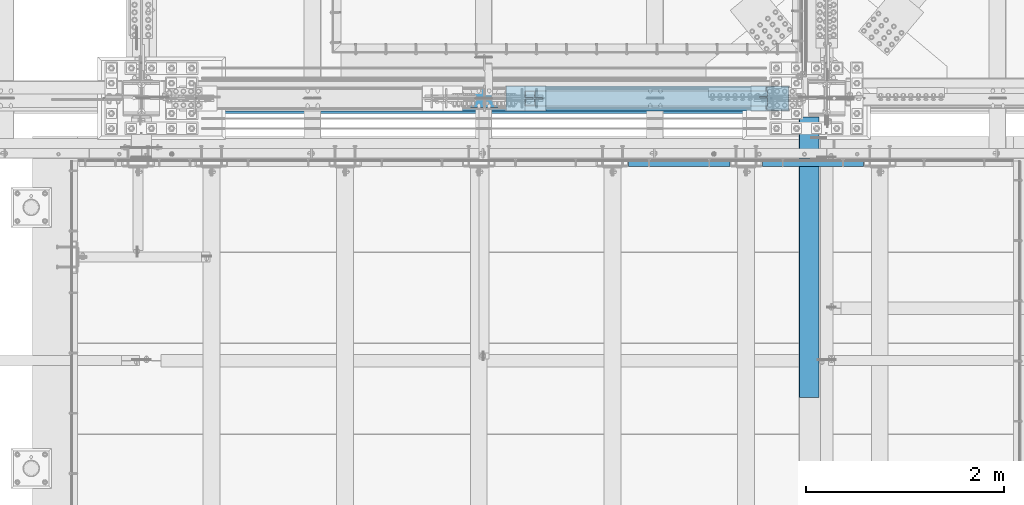
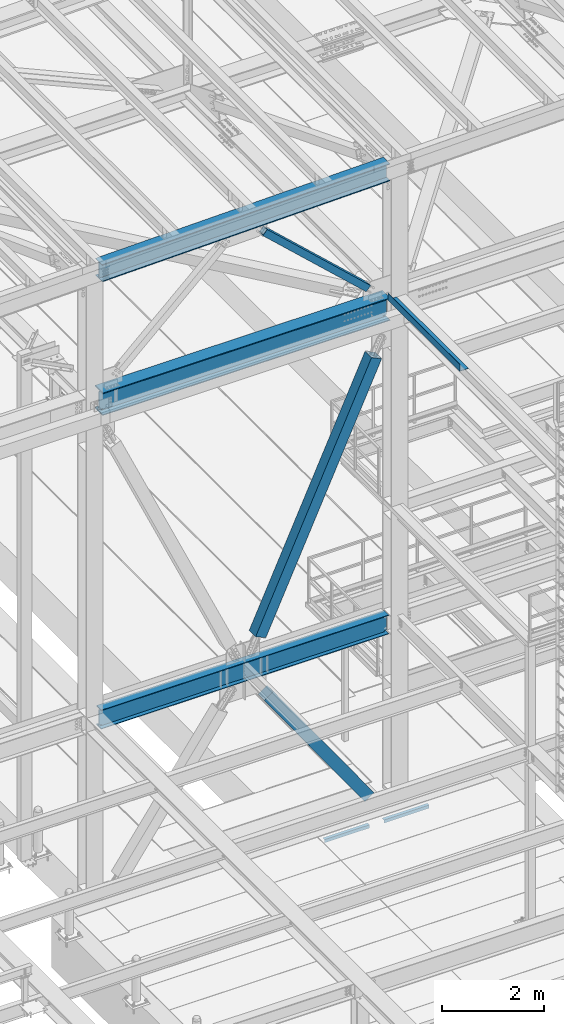
# One storey, part 1779 of 3843: 6 beams, 3 members, 9 elements without a shape of their own.
"""IFC2X3 building model written with IfcOpenShell, lengths in millimetres."""

from ifc_helpers import new_model, si_unit, frame, origin_with_axes, place, context, subcontext, project, spatial, faceted_brep, material, type_object, element, aggregate, save


model = new_model("IFC2X3")

# Units and contexts
model_context = context("Model", 3, precision=1e-05, world=origin_with_axes())
body_context = subcontext(model_context, "Body", "Model", "MODEL_VIEW")
ifc_project = project(units=[si_unit("LENGTHUNIT", "METRE", prefix="MILLI"), si_unit("AREAUNIT", "SQUARE_METRE"), si_unit("VOLUMEUNIT", "CUBIC_METRE"), si_unit("MASSUNIT", "GRAM", prefix="KILO"), si_unit("TIMEUNIT", "SECOND"), si_unit("PLANEANGLEUNIT", "RADIAN"), si_unit("SOLIDANGLEUNIT", "STERADIAN"), si_unit("THERMODYNAMICTEMPERATUREUNIT", "DEGREE_CELSIUS"), si_unit("LUMINOUSINTENSITYUNIT", "LUMEN")], contexts=[model_context])

# Site, building, storey
site_placement = place(None, origin_with_axes())
site = spatial("IfcSite", under=ifc_project, at=site_placement, CompositionType="ELEMENT")
building_placement = place(site_placement, origin_with_axes())
building = spatial("IfcBuilding", under=site, at=building_placement, Name="Undefined", CompositionType="ELEMENT")
storey_placement = place(building_placement, origin_with_axes())
storey = spatial("IfcBuildingStorey", under=building, at=storey_placement, Name="Undefined", CompositionType="ELEMENT", Elevation=0.0)

# Assembly, beam
assembly_1_placement = place(storey_placement, origin_with_axes())
assembly_1 = element("IfcElementAssembly", 1, at=assembly_1_placement, inside=storey, Name="ANGLE", AssemblyPlace="NOTDEFINED", PredefinedType="RIGID_FRAME")
ifc_material_1 = material(Name="STEEL/A36")
beam_type_1 = type_object("IfcBeamType", Name="L3X3X1/4", PredefinedType="NOTDEFINED")
beam_1_placement = place(assembly_1_placement, frame((48345.7242797851, 24961.8499971387, 30365.7000030518), z_axis=(0.0, 0.0, -1.0), x_axis=(1.0, 0.0, 0.0)))
beam_1 = element("IfcBeam", 2, at=beam_1_placement, type_object=beam_type_1, material=ifc_material_1, Name="ANGLE", ObjectType="L3X3X1/4", context=body_context, shape_type="Brep", body=[
    faceted_brep([(0.0, 38.0999999999985, -38.0999999999985), (0.0, 38.0999999999985, 38.0999999999985), (1022.33317453146, 38.1000000000004, 38.0999999999985), (1022.33317453146, 38.1000000000004, -38.0999999999985), (0.0, 31.75, 38.0999999999985), (1022.33317453146, 31.75, 38.0999999999985), (0.0, 31.75, -31.75), (1022.33317453146, 31.75, -31.75), (0.0, -38.0999999999985, -31.75), (1022.33317453146, -38.1000000000004, -31.75), (0.0, -38.0999999999985, -38.0999999999985), (1022.33317453146, -38.1000000000004, -38.0999999999985)], [[[0, 1, 2, 3]], [[1, 4, 5, 2]], [[4, 6, 7, 5]], [[6, 8, 9, 7]], [[8, 10, 11, 9]], [[10, 0, 3, 11]], [[5, 7, 9, 11, 3, 2]], [[10, 8, 6, 4, 1, 0]]]),
])
aggregate(assembly_1, [beam_1])

assembly_2_placement = place(storey_placement, origin_with_axes())
assembly_2 = element("IfcElementAssembly", 3, at=assembly_2_placement, inside=storey, Name="ANGLE", AssemblyPlace="NOTDEFINED", PredefinedType="RIGID_FRAME")
beam_2_placement = place(assembly_2_placement, frame((46993.1742797851, 24961.8499970339, 30365.7000030518), z_axis=(0.0, 0.0, -1.0), x_axis=(1.0, 0.0, 0.0)))
beam_2 = element("IfcBeam", 4, at=beam_2_placement, type_object=beam_type_1, material=ifc_material_1, Name="ANGLE", ObjectType="L3X3X1/4", context=body_context, shape_type="Brep", body=[
    faceted_brep([(0.0, 38.0999999999985, -38.0999999999985), (0.0, 38.0999999999985, 38.0999999999985), (1022.33317453146, 38.1000000000004, 38.0999999999985), (1022.33317453146, 38.1000000000004, -38.0999999999985), (0.0, 31.75, 38.0999999999985), (1022.33317453146, 31.75, 38.0999999999985), (0.0, 31.75, -31.75), (1022.33317453146, 31.75, -31.75), (0.0, -38.0999999999985, -31.75), (1022.33317453146, -38.1000000000004, -31.75), (0.0, -38.0999999999985, -38.0999999999985), (1022.33317453146, -38.1000000000004, -38.0999999999985)], [[[0, 1, 2, 3]], [[1, 4, 5, 2]], [[4, 6, 7, 5]], [[6, 8, 9, 7]], [[8, 10, 11, 9]], [[10, 0, 3, 11]], [[5, 7, 9, 11, 3, 2]], [[10, 8, 6, 4, 1, 0]]]),
])
aggregate(assembly_2, [beam_2])

assembly_3_placement = place(storey_placement, origin_with_axes())
assembly_3 = element("IfcElementAssembly", 5, at=assembly_3_placement, inside=storey, Name="BEAM", AssemblyPlace="NOTDEFINED", PredefinedType="RIGID_FRAME")
ifc_material_2 = material(Name="STEEL/A992")
beam_type_2 = type_object("IfcBeamType", Name="W21X101", PredefinedType="NOTDEFINED")
beam_3_placement = place(assembly_3_placement, frame((42062.4, 25615.8999999454, 42197.3375000034), z_axis=(0.0, 0.0, 1.0), x_axis=(1.0, 0.0, 0.0)))
beam_3 = element("IfcBeam", 6, at=beam_3_placement, type_object=beam_type_2, material=ifc_material_2, Name="BEAM", ObjectType="W21X101", context=body_context, shape_type="Brep", body=[
    faceted_brep([(6740.525, 6.35000000000218, 215.900000000001), (6733.19265158327, -6.34999999999854, 215.900000000001), (6733.19265158327, -6.34999999999854, -215.900000000001), (6740.525, 6.34999999999854, -215.900000000001), (6728.61039888389, 155.575000000001, 271.462500000001), (6740.525, 155.575000000001, 250.824999999997), (193.675000000003, 155.575000000001, 250.824999999997), (205.589601116109, 155.575000000001, 271.462500000001), (6740.525, 6.34999999999854, 250.824999999997), (193.675000000003, 6.35000000000036, 250.824999999997), (6740.525, -155.575000000001, -271.462500000001), (6728.61038401834, -155.575000000001, -250.824999999997), (205.589615981677, -155.575000000001, -250.824999999997), (193.675000000003, -155.575000000001, -271.462500000001), (6740.525, 155.575000000001, -271.462500000001), (193.675000000003, 155.575000000001, -271.462500000001), (6728.61038401834, 155.575000000001, -250.824999999997), (205.589615981677, 155.575000000001, -250.824999999997), (6728.61038401834, 6.34999999999854, -250.824999999997), (205.589615981677, 6.35000000000036, -250.824999999997), (6658.64956922777, -6.34999999999854, -217.357163726287), (6658.64956922777, 6.34999999999854, -217.357163726287), (6663.71273441853, 6.34999999999854, -215.900000000001), (6663.71273441853, -6.34999999999854, -215.900000000001), (6655.13556119223, -6.34999999999854, -221.282812131343), (6655.13556119223, 6.34999999999854, -221.282812131343), (6654.2458778181, -6.34999999999854, -226.475829690324), (6654.2458778181, 6.34999999999854, -226.475829690324), (6656.25273210119, -6.34999999999854, -231.347328818971), (6656.25273210119, 6.34999999999854, -231.347328818971), (6660.54209456492, -6.34999999999854, -234.406795689014), (6660.54209456492, 6.34999999999854, -234.406795689014), (6705.92699999999, -6.34999999999854, -250.428), (6705.92699999999, 6.34999999999854, -250.428), (6728.38119200916, -6.34999999999854, -250.428), (6728.38119200916, 6.34999999999854, -250.428), (6728.61038401834, -6.34999999999854, -250.824999999997), (205.589615981677, -6.35000000000036, -250.824999999997), (205.818807990843, -6.35000000000036, -250.428), (205.818807990843, 6.35000000000036, -250.428), (228.27300000003, -6.35000000000036, -250.428), (228.27300000003, 6.35000000000036, -250.428), (273.657905435088, -6.35000000000036, -234.406795689014), (273.657905435088, 6.35000000000036, -234.406795689014), (277.94726789881, -6.35000000000036, -231.347328818971), (277.94726789881, 6.35000000000036, -231.347328818971), (279.954122181924, -6.35000000000036, -226.475829690324), (279.954122181924, 6.35000000000036, -226.475829690324), (279.064438807793, -6.35000000000036, -221.282812131343), (279.064438807793, 6.35000000000036, -221.282812131343), (275.550430772229, -6.35000000000036, -217.357163726287), (275.550430772229, 6.35000000000036, -217.357163726287), (270.487265581483, -6.35000000000036, -215.900000000001), (270.487265581483, 6.35000000000036, -215.900000000001), (201.007348417363, -6.35000000000036, -215.900000000001), (193.675000000003, 6.35000000000036, -215.900000000001), (201.007348417363, -6.35000000035689, 215.900000000001), (193.675000000003, 6.35000000000036, 215.900000000001), (270.814265581474, -6.35000000000036, 215.900000000001), (270.814265581474, 6.35000000000036, 215.900000000001), (275.877430772234, -6.35000000000036, 217.357163726287), (275.877430772234, 6.35000000000036, 217.357163726287), (279.391438807783, -6.35000000000036, 221.282812131351), (279.391438807783, 6.35000000000036, 221.282812131351), (280.281122181914, -6.35000000000036, 226.475829690324), (280.281122181914, 6.35000000000036, 226.475829690324), (278.274267898814, -6.35000000000036, 231.347328818971), (278.274267898814, 6.35000000000036, 231.347328818971), (273.984905435093, -6.35000000000036, 234.406795689014), (273.984905435093, 6.35000000000036, 234.406795689014), (228.60000000002, -6.35000000000036, 250.428), (228.60000000002, 6.35000000000036, 250.428), (193.675000000003, -6.35000000000036, 250.428), (193.675000000003, 6.35000000000036, 250.428), (193.675000000003, -6.35000000000036, 250.824999999997), (6740.525, -155.575000000001, 250.824999999997), (6728.61039888389, -155.575000000001, 271.462500000001), (205.589601116109, -155.575000000001, 271.462500000001), (193.675000000003, -155.575000000001, 250.824999999997), (6740.525, -6.34999999999854, 250.824999999997), (6740.525, -6.34999999999854, 250.428), (6740.525, 6.34999999999854, 250.428), (6705.59999999999, -6.34999999999854, 250.428), (6705.59999999999, 6.34999999999854, 250.428), (6660.21509456492, -6.34999999999854, 234.406795689014), (6660.21509456492, 6.34999999999854, 234.406795689014), (6655.9257321012, -6.34999999999854, 231.347328818971), (6655.9257321012, 6.34999999999854, 231.347328818971), (6653.9188778181, -6.34999999999854, 226.475829690324), (6653.9188778181, 6.34999999999854, 226.475829690324), (6654.80856119223, -6.34999999999854, 221.282812131351), (6654.80856119223, 6.34999999999854, 221.282812131351), (6658.32256922778, -6.34999999999854, 217.357163726287), (6658.32256922778, 6.34999999999854, 217.357163726287), (6663.38573441853, -6.34999999999854, 215.900000000001), (6663.38573441853, 6.34999999999854, 215.900000000001)], [[[0, 1, 2, 3]], [[4, 5, 6, 7]], [[5, 8, 9, 6]], [[10, 11, 12, 13]], [[14, 10, 13, 15]], [[16, 14, 15, 17]], [[18, 16, 17, 19]], [[20, 21, 22, 23]], [[24, 25, 21, 20]], [[26, 27, 25, 24]], [[28, 29, 27, 26]], [[30, 31, 29, 28]], [[32, 33, 31, 30]], [[33, 32, 34, 35]], [[10, 14, 16, 18, 35, 34, 36, 11]], [[11, 36, 37, 12]], [[38, 39, 19, 17, 15, 13, 12, 37]], [[40, 41, 39, 38]], [[42, 43, 41, 40]], [[44, 45, 43, 42]], [[46, 47, 45, 44]], [[48, 49, 47, 46]], [[50, 51, 49, 48]], [[52, 53, 51, 50]], [[53, 52, 54, 55]], [[56, 57, 55, 54]], [[58, 59, 57, 56]], [[60, 61, 59, 58]], [[62, 63, 61, 60]], [[64, 65, 63, 62]], [[66, 67, 65, 64]], [[68, 69, 67, 66]], [[70, 71, 69, 68]], [[71, 70, 72, 73]], [[73, 72, 74, 9]], [[75, 76, 77, 78]], [[79, 75, 78, 74]], [[77, 7, 6, 9, 74, 78]], [[76, 4, 7, 77]], [[75, 79, 8, 5, 4, 76]], [[80, 81, 8, 79]], [[82, 83, 81, 80]], [[84, 85, 83, 82]], [[86, 87, 85, 84]], [[88, 89, 87, 86]], [[90, 91, 89, 88]], [[92, 93, 91, 90]], [[94, 95, 93, 92]], [[22, 21, 25, 27, 29, 31, 33, 35, 18, 19, 39, 41, 43, 45, 47, 49, 51, 53, 55, 57, 59, 61, 63, 65, 67, 69, 71, 73, 9, 8, 81, 83, 85, 87, 89, 91, 93, 95, 0, 3]], [[23, 22, 3, 2]], [[94, 92, 90, 88, 86, 84, 82, 80, 79, 74, 72, 70, 68, 66, 64, 62, 60, 58, 56, 54, 52, 50, 48, 46, 44, 42, 40, 38, 37, 36, 34, 32, 30, 28, 26, 24, 20, 23, 2, 1]], [[95, 94, 1, 0]]]),
])
aggregate(assembly_3, [beam_3])

# Assembly, member
assembly_4_placement = place(storey_placement, origin_with_axes())
assembly_4 = element("IfcElementAssembly", 7, at=assembly_4_placement, inside=storey, Name="None", AssemblyPlace="NOTDEFINED", PredefinedType="RIGID_FRAME")
member_type_1 = type_object("IfcMemberType", Name="HSS10X10X1/4", PredefinedType="NOTDEFINED")
member_1_placement = place(assembly_4_placement, frame((48336.5971275639, 25615.9, 30613.0908745675), z_axis=(0.0, 1.0, 0.0), x_axis=(-0.577430334981806, 0.0, 0.816439959974278)))
member_1 = element("IfcMember", 8, at=member_1_placement, type_object=member_type_1, material=ifc_material_2, Name="None", ObjectType="HSS10X10X1/4", context=body_context, shape_type="Brep", body=[
    faceted_brep([(2.00088834390044e-10, 120.650000000089, -120.649999999994), (-2.03726813197136e-10, -120.650000000081, -120.649999999994), (3956.04999999908, -120.650000004462, -120.650000000001), (3956.04999999883, 120.64999999624, -120.650000000001), (-2.03726813197136e-10, -120.650000000081, 120.649999999994), (3956.04999999908, -120.650000004462, 120.650000000001), (2.00088834390044e-10, 120.650000000089, 120.649999999994), (3956.04999999883, 120.64999999624, 120.650000000001), (2.16459739021957e-10, 127.000000000087, -127.0), (2.16459739021957e-10, 127.000000000087, 127.0), (3956.04999999882, 126.999999996267, 127.0), (3956.04999999882, 126.999999996267, -127.0), (-2.14640749618411e-10, -127.00000000008, 127.0), (3956.04999999909, -127.000000004475, 127.0), (-2.14640749618411e-10, -127.00000000008, -127.0), (3956.04999999909, -127.000000004475, -127.0)], [[[0, 1, 2, 3]], [[1, 4, 5, 2]], [[4, 6, 7, 5]], [[6, 0, 3, 7]], [[8, 9, 10, 11]], [[9, 12, 13, 10]], [[12, 14, 15, 13]], [[14, 8, 11, 15]], [[13, 15, 11, 10], [5, 7, 3, 2]], [[14, 12, 9, 8], [6, 4, 1, 0]]]),
])
aggregate(assembly_4, [member_1])

assembly_5_placement = place(storey_placement, origin_with_axes())
assembly_5 = element("IfcElementAssembly", 9, at=assembly_5_placement, inside=storey, Name="None", AssemblyPlace="NOTDEFINED", PredefinedType="RIGID_FRAME")
member_2_placement = place(assembly_5_placement, frame((45866.2920858545, 25615.9, 35321.839765117), z_axis=(0.0, -1.0, 0.0), x_axis=(0.414360348069936, 0.0, 0.910112906153606)))
member_2 = element("IfcMember", 10, at=member_2_placement, type_object=member_type_1, material=ifc_material_2, Name="None", ObjectType="HSS10X10X1/4", context=body_context, shape_type="Brep", body=[
    faceted_brep([(2.00088834390044e-10, 120.650000000089, -120.649999999994), (-2.03726813197136e-10, -120.650000000081, -120.649999999994), (6356.35072209054, -120.65000000098, -120.650000000001), (6356.35072209057, 120.649999998823, -120.650000000001), (-2.03726813197136e-10, -120.650000000081, 120.649999999994), (6356.35072209054, -120.65000000098, 120.650000000001), (2.00088834390044e-10, 120.650000000089, 120.649999999994), (6356.35072209057, 120.649999998823, 120.650000000001), (2.16459739021957e-10, 127.000000000087, -127.0), (2.16459739021957e-10, 127.000000000087, 127.0), (6356.35072209059, 126.99999999881, 127.0), (6356.35072209059, 126.99999999881, -127.0), (-2.14640749618411e-10, -127.00000000008, 127.0), (6356.35072209054, -127.000000000979, 127.0), (-2.14640749618411e-10, -127.00000000008, -127.0), (6356.35072209054, -127.000000000979, -127.0)], [[[0, 1, 2, 3]], [[1, 4, 5, 2]], [[4, 6, 7, 5]], [[6, 0, 3, 7]], [[8, 9, 10, 11]], [[9, 12, 13, 10]], [[12, 14, 15, 13]], [[14, 8, 11, 15]], [[13, 15, 11, 10], [5, 7, 3, 2]], [[14, 12, 9, 8], [6, 4, 1, 0]]]),
])
aggregate(assembly_5, [member_2])

# Assembly, beam
assembly_6_placement = place(storey_placement, origin_with_axes())
assembly_6 = element("IfcElementAssembly", 11, at=assembly_6_placement, inside=storey, Name="BEAM", AssemblyPlace="NOTDEFINED", PredefinedType="RIGID_FRAME")
beam_type_3 = type_object("IfcBeamType", PredefinedType="NOTDEFINED")
beam_4_placement = place(assembly_6_placement, frame((48917.225, 24006.175, 42471.975), z_axis=(0.0, -1.0, 0.0), x_axis=(-1.0, 0.0, 0.0)))
beam_4 = element("IfcBeam", 12, at=beam_4_placement, type_object=beam_type_3, material=ifc_material_1, Name="BENT_PLATE", context=body_context, shape_type="Brep", body=[
    faceted_brep([(193.674999999996, -161.924999999996, 1416.05000004769), (196.849999952312, -161.924999999996, 1419.225), (196.849999952312, -4.76720742881298e-08, 1419.225), (193.674999999996, -3.17500000000291, 1416.05000004769), (0.0, -4.76720742881298e-08, 1419.225), (0.0, -3.17500000000291, 1416.05000004767), (0.0, -3.17500000000291, -1419.225), (193.674999999996, -3.17500000000291, -1419.225), (0.0, 3.17500000000291, 1419.225), (0.0, 3.17500000000291, -1419.225), (200.025000000001, 3.17500000000291, 1419.225), (200.025000000001, 3.17500000000291, -1419.225), (200.025000000001, -161.924999999996, 1419.225), (200.025000000001, -161.924999999996, -1419.225), (193.674999999996, -161.924999999996, -1419.225)], [[[0, 1, 2, 3]], [[3, 2, 4, 5]], [[6, 7, 3, 5]], [[8, 9, 6, 5, 4]], [[9, 8, 10, 11]], [[11, 10, 12, 13]], [[1, 12, 10, 8, 4, 2]], [[7, 14, 0, 3]], [[7, 6, 9, 11, 13, 14]], [[14, 13, 12, 1, 0]]]),
])
aggregate(assembly_6, [beam_4])

# Assembly, member
assembly_7_placement = place(storey_placement, origin_with_axes())
assembly_7 = element("IfcElementAssembly", 13, at=assembly_7_placement, inside=storey, AssemblyPlace="NOTDEFINED", PredefinedType="RIGID_FRAME")
ifc_material_3 = material()
member_type_2 = type_object("IfcMemberType", Name="HSS6X6X3/8", PredefinedType="NOTDEFINED")
member_3_placement = place(assembly_7_placement, frame((45529.5000013116, 25615.9000000156, 45399.7936535037), z_axis=(0.678515287903955, 0.0, 0.734586280895997), x_axis=(0.734586280896004, 0.0, -0.678515287903948)))
member_3 = element("IfcMember", 14, at=member_3_placement, type_object=member_type_2, material=ifc_material_3, ObjectType="HSS6X6X3/8", context=body_context, shape_type="Brep", body=[
    faceted_brep([(632.236458029127, 7.9374999298343, 76.1999999999971), (632.236458029123, 7.9374999298343, 66.6750000000102), (732.248958025573, 7.9374999298343, 66.6750000000466), (732.24895802557, 7.9374999298343, 76.2000000000189), (735.286507769944, 7.33329371914442, 66.6750000000466), (735.286507769944, 7.33329371914442, 76.2000000000189), (737.861618101195, 5.61266000550313, 66.6750000000466), (737.861618101198, 5.61266000550313, 76.2000000000189), (739.582251814832, 3.03754967423083, 66.6750000000466), (739.582251814822, 3.03754967423083, 76.2000000000189), (732.24895802557, -7.9375000701657, 76.2000000000189), (732.248958025573, -7.9375000701657, 66.6750000000466), (632.236458029123, -7.9375000701657, 66.6750000000102), (632.236458029127, -7.9375000701657, 76.1999999999971), (735.286507769944, -7.33329385947582, 76.2000000000189), (735.286507769944, -7.33329385947582, 66.6750000000466), (737.861618101198, -5.61266014583452, 76.2000000000189), (737.861618101195, -5.61266014583452, 66.6750000000466), (739.582251814822, -3.03754981456223, 76.2000000000189), (739.582251814832, -3.03754981456223, 66.6750000000466), (740.186458025511, -7.01656972523779e-08, 76.2000000000189), (740.186458025515, -7.01656972523779e-08, 66.6750000000393), (632.236458029127, 7.9374999298343, -66.6749999996464), (632.236458029127, 7.9374999298343, -76.1999999996115), (732.248958025613, 7.9374999298343, -76.1999999995824), (732.248958025613, 7.9374999298343, -66.67499999961), (735.286507769988, 7.33329371914442, -76.1999999995824), (735.286507769988, 7.33329371914442, -66.67499999961), (737.861618101238, 5.61266000550313, -76.1999999995824), (737.861618101235, 5.61266000550313, -66.6749999996027), (739.582251814869, 3.03754967423083, -76.1999999995824), (739.582251814865, 3.03754967423083, -66.6749999996027), (732.248958025613, -7.9375000701657, -66.67499999961), (732.248958025613, -7.9375000701657, -76.1999999995824), (632.236458029127, -7.9375000701657, -76.1999999996115), (632.236458029127, -7.9375000701657, -66.6749999996464), (735.286507769988, -7.33329385947582, -66.67499999961), (735.286507769988, -7.33329385947582, -76.1999999995824), (737.861618101235, -5.61266014583452, -66.6749999996027), (737.861618101238, -5.61266014583452, -76.1999999995824), (739.582251814865, -3.03754981456223, -66.6749999996027), (739.582251814869, -3.03754981456223, -76.1999999995824), (740.186458025548, -7.01656972523779e-08, -66.67499999961), (740.186458025551, -7.01656972523779e-08, -76.1999999995896), (632.236458029123, 66.6749999999993, 66.6750000000102), (632.236458029127, 66.6749999999993, -66.6749999996464), (3832.0470759523, 66.6749999999993, -66.6749999987296), (3832.04707595231, 66.6749999999993, 66.675000000927), (632.236458029127, 76.2000000000007, -76.1999999996115), (3832.0470759523, 76.2000000000007, -76.1999999987092), (3832.0470759523, 20.6375000000007, -76.1999999987092), (3732.03457595294, 20.6375000000007, -76.1999999987311), (3728.99702620856, 20.0332937893108, -76.1999999987311), (3726.42191587731, 18.3126600756696, -76.1999999987383), (3724.70128216368, 15.7375497443973, -76.1999999987383), (3724.097075953, 12.7000000000007, -76.1999999987383), (3724.70128216368, 9.6624502556042, -76.1999999987383), (3726.42191587731, 7.0873399243319, -76.1999999987383), (3728.99702620856, 5.36670621069061, -76.1999999987311), (3732.03457595294, 4.76250000000073, -76.1999999987311), (3832.0470759523, 4.76250000000073, -76.1999999987092), (3832.0470759523, -76.2000000000007, -76.1999999987092), (632.236458029127, -76.2000000000007, -76.1999999996115), (3832.0470759523, 20.6375000000007, -66.6749999987296), (3732.03457595294, 20.6375000000007, -66.6749999987587), (3728.99702620856, 20.0332937893108, -66.6749999987587), (3726.42191587731, 18.3126600756696, -66.6749999987587), (3724.70128216369, 15.7375497443973, -66.6749999987587), (3724.09707595299, 12.7000000000007, -66.6749999987587), (3724.70128216369, 9.6624502556042, -66.6749999987587), (3726.42191587731, 7.0873399243319, -66.6749999987587), (3728.99702620856, 5.36670621069061, -66.6749999987587), (3732.03457595294, 4.76250000000073, -66.6749999987587), (3832.0470759523, 4.76250000000073, -66.6749999987296), (632.236458029127, -66.6749999999993, -66.6749999996464), (632.236458029123, -66.6749999999993, 66.6750000000102), (3832.04707595231, -66.6749999999993, 66.675000000927), (3832.0470759523, -66.6749999999993, -66.6749999987296), (3728.99702620852, 20.0332937893108, 76.2000000008775), (3728.99702620852, 20.0332937893108, 66.6750000008979), (3732.0345759529, 20.6375000000007, 66.6750000008979), (3732.0345759529, 20.6375000000007, 76.2000000008775), (3726.42191587727, 18.3126600756696, 76.2000000008629), (3726.42191587727, 18.3126600756696, 66.6750000008833), (3724.70128216364, 15.7375497443973, 76.2000000008775), (3724.70128216365, 15.7375497443973, 66.6750000008979), (3724.09707595296, 12.7000000000007, 76.2000000008702), (3724.09707595296, 12.7000000000007, 66.6750000008906), (3724.70128216364, 9.6624502556042, 76.2000000008775), (3724.70128216365, 9.6624502556042, 66.6750000008979), (3726.42191587727, 7.0873399243319, 76.2000000008629), (3726.42191587727, 7.0873399243319, 66.6750000008833), (3728.99702620852, 5.36670621069061, 76.2000000008775), (3728.99702620852, 5.36670621069061, 66.6750000008979), (3732.0345759529, 4.76250000000073, 76.2000000008775), (3732.0345759529, 4.76250000000073, 66.6750000008979), (3832.0470759523, 4.76250000000073, 76.2000000009066), (3832.04707595231, 4.76250000000073, 66.675000000927), (3832.0470759523, -76.2000000000007, 76.2000000009066), (632.236458029127, -76.2000000000007, 76.1999999999971), (3832.04707595231, 20.6375000000007, 66.675000000927), (3832.0470759523, 20.6375000000007, 76.2000000009066), (3832.0470759523, 76.2000000000007, 76.2000000009066), (632.236458029127, 76.2000000000007, 76.1999999999971)], [[[0, 1, 2, 3]], [[3, 2, 4, 5]], [[5, 4, 6, 7]], [[7, 6, 8, 9]], [[10, 11, 12, 13]], [[14, 15, 11, 10]], [[16, 17, 15, 14]], [[18, 19, 17, 16]], [[20, 21, 19, 18]], [[9, 8, 21, 20]], [[22, 23, 24, 25]], [[25, 24, 26, 27]], [[27, 26, 28, 29]], [[29, 28, 30, 31]], [[32, 33, 34, 35]], [[36, 37, 33, 32]], [[38, 39, 37, 36]], [[40, 41, 39, 38]], [[42, 43, 41, 40]], [[31, 30, 43, 42]], [[44, 45, 46, 47]], [[28, 26, 24, 23, 48, 49, 50, 51, 52, 53, 54, 55, 56, 57, 58, 59, 60, 61, 62, 34, 33, 37, 39, 41, 43, 30]], [[63, 64, 51, 50]], [[65, 52, 51, 64]], [[66, 53, 52, 65]], [[67, 54, 53, 66]], [[68, 55, 54, 67]], [[69, 56, 55, 68]], [[70, 57, 56, 69]], [[71, 58, 57, 70]], [[72, 59, 58, 71]], [[73, 60, 59, 72]], [[74, 75, 76, 77]], [[78, 79, 80, 81]], [[82, 83, 79, 78]], [[84, 85, 83, 82]], [[86, 87, 85, 84]], [[88, 89, 87, 86]], [[90, 91, 89, 88]], [[92, 93, 91, 90]], [[94, 95, 93, 92]], [[96, 97, 95, 94]], [[98, 61, 60, 73, 77, 76, 97, 96]], [[99, 62, 61, 98]], [[75, 74, 35, 34, 62, 99, 13, 12]], [[6, 4, 2, 1, 44, 47, 100, 80, 79, 83, 85, 87, 89, 91, 93, 95, 97, 76, 75, 12, 11, 15, 17, 19, 21, 8]], [[101, 81, 80, 100]], [[47, 46, 63, 50, 49, 102, 101, 100]], [[48, 103, 102, 49]], [[16, 14, 10, 13, 99, 98, 96, 94, 92, 90, 88, 86, 84, 82, 78, 81, 101, 102, 103, 0, 3, 5, 7, 9, 20, 18]], [[103, 48, 23, 22, 45, 44, 1, 0]], [[38, 36, 32, 35, 74, 77, 73, 72, 71, 70, 69, 68, 67, 66, 65, 64, 63, 46, 45, 22, 25, 27, 29, 31, 42, 40]]]),
])
aggregate(assembly_7, [member_3])

# Assembly, beam
assembly_8_placement = place(storey_placement, origin_with_axes())
assembly_8 = element("IfcElementAssembly", 15, at=assembly_8_placement, inside=storey, Name="BEAM", AssemblyPlace="NOTDEFINED", PredefinedType="RIGID_FRAME")
beam_type_4 = type_object("IfcBeamType", Name="W16X67", PredefinedType="NOTDEFINED")
beam_5_placement = place(assembly_8_placement, frame((42066.7988430314, 25615.9, 45326.5338700322), z_axis=(-0.0211520980073474, 0.0, 0.999776269347241), x_axis=(0.999776270257024, 0.0, 0.0211520550054619)))
beam_5 = element("IfcBeam", 16, at=beam_5_placement, type_object=beam_type_4, material=ifc_material_2, Name="BEAM", ObjectType="W16X67", context=body_context, shape_type="Brep", body=[
    faceted_brep([(188.094396478875, -130.174999999999, -207.962499999492), (188.094396478875, 130.174999999999, -207.962499999492), (6730.05803391119, 130.174999999999, -207.9624999929), (6730.05803391119, -130.174999999999, -207.9624999929), (188.463847647872, -130.174999999999, -190.49999999952), (188.463847647872, -4.76250000000073, -190.49999999952), (196.524600426201, -4.76250000000073, 190.499999999869), (196.524600426201, -130.174999999999, 190.499999999869), (196.894051595213, -130.174999999999, 207.962499999841), (196.894051595213, 130.174999999999, 207.962499999841), (196.524600426201, 130.174999999999, 190.499999999869), (196.524600426201, 4.76250000000073, 190.499999999869), (195.989385299312, 4.76250000000073, 165.202490022384), (189.242289076908, 4.76250000000073, -153.706144372954), (188.463847647872, 4.76250000000073, -190.49999999952), (188.463847647872, 130.174999999999, -190.49999999952), (6730.4274850802, -130.174999999999, -190.499999992935), (6730.4274850802, -4.76250000000073, -190.499999992935), (6738.48823785847, -4.76250000000073, 190.500000006461), (6738.48823785847, -130.174999999999, 190.500000006461), (6738.85768902747, -130.174999999999, 207.962500006433), (6738.85768902747, 130.174999999999, 207.962500006433), (6738.48823785847, 130.174999999999, 190.500000006461), (6738.48823785847, 4.76250000000073, 190.500000006461), (6737.91323894299, 4.76250000000073, 163.322068512651), (6731.16614272063, 4.76250000000073, -155.586565882695), (6730.4274850802, 4.76250000000073, -190.499999992935), (6730.4274850802, 130.174999999999, -190.499999992935)], [[[0, 1, 2, 3]], [[0, 4, 5, 6, 7, 8, 9, 10, 11, 12, 13, 14, 15, 1]], [[5, 4, 16, 17]], [[6, 5, 17, 18]], [[7, 6, 18, 19]], [[8, 7, 19, 20]], [[9, 8, 20, 21]], [[10, 9, 21, 22]], [[11, 10, 22, 23]], [[14, 13, 12, 11, 23, 24, 25, 26]], [[15, 14, 26, 27]], [[1, 15, 27, 2]], [[26, 25, 24, 23, 22, 21, 20, 19, 18, 17, 16, 3, 2, 27]], [[4, 0, 3, 16]]]),
])
aggregate(assembly_8, [beam_5])

assembly_9_placement = place(storey_placement, origin_with_axes())
assembly_9 = element("IfcElementAssembly", 17, at=assembly_9_placement, inside=storey, Name="BEAM", AssemblyPlace="NOTDEFINED", PredefinedType="RIGID_FRAME")
beam_type_5 = type_object("IfcBeamType", Name="W18X50", PredefinedType="NOTDEFINED")
beam_6_placement = place(assembly_9_placement, frame((42062.4, 25615.9, 34582.1), z_axis=(0.0, 0.0, 1.0), x_axis=(1.0, 0.0, 0.0)))
beam_6 = element("IfcBeam", 18, at=beam_6_placement, type_object=beam_type_5, material=ifc_material_2, Name="BEAM", ObjectType="W18X50", context=body_context, shape_type="Brep", body=[
    faceted_brep([(199.174261312706, -4.76250000012442, 185.737500000003), (193.674999999996, 4.76250000000073, 185.737500000003), (193.674999999996, 4.76250000000073, -185.737500000003), (199.174261312706, -4.76250000000073, -185.737500000003), (249.127324331712, -4.76250000000073, -185.737500000003), (249.127324331712, 4.76250000000073, -185.737500000003), (254.291860659658, 4.76250000000073, -187.25917641812), (254.291860659658, -4.76250000000073, -187.25917641812), (257.806265028448, 4.76250000000073, -191.338011611741), (257.806265028448, -4.76250000000073, -191.338011611741), (258.547642642101, 4.76250000000073, -196.670768294556), (258.547642642101, -4.76250000000073, -196.670768294556), (256.279114366378, 4.76250000000073, -201.553566064933), (256.279114366378, -4.76250000000073, -201.553566064933), (251.725502483539, 4.76250000000073, -204.426291847973), (251.725502483539, -4.76250000000073, -204.426291847973), (218.256999999998, 4.76250000000073, -213.915500000003), (218.256999999998, -4.76250000000073, -213.915500000003), (202.152810053223, 4.76250000000073, -213.915500000003), (202.152810053223, -4.76250000000073, -213.915500000003), (6732.27637989355, 4.76250000000073, -214.3125), (6732.27637989355, 95.25, -214.3125), (201.923620106449, 95.25, -214.3125), (201.923620106449, 4.76250000000073, -214.3125), (6740.525, 95.25, -228.599999999999), (193.674999999996, 95.25, -228.599999999999), (6740.525, -95.25, -228.599999999999), (193.674999999996, -95.25, -228.599999999999), (6732.27637989355, -95.25, -214.3125), (201.923620106449, -95.25, -214.3125), (201.923620106449, -4.76250000000073, -214.3125), (6732.27637989355, -4.76250000000073, -214.3125), (6732.04718994677, 4.76250000000073, -213.915500000003), (6732.04718994677, -4.76250000000073, -213.915500000003), (6715.943, 4.76250000000073, -213.915500000003), (6715.943, -4.76250000000073, -213.915500000003), (6682.47449751646, 4.76250000000073, -204.426291847973), (6682.47449751646, -4.76250000000073, -204.426291847973), (6677.92088563362, 4.76250000000073, -201.553566064933), (6677.92088563362, -4.76250000000073, -201.553566064933), (6675.6523573579, 4.76250000000073, -196.670768294556), (6675.6523573579, -4.76250000000073, -196.670768294556), (6676.39373497155, 4.76250000000073, -191.338011611741), (6676.39373497155, -4.76250000000073, -191.338011611741), (6679.90813934034, 4.76250000000073, -187.25917641812), (6679.90813934034, -4.76250000000073, -187.25917641812), (6685.07267566829, 4.76250000000073, -185.737500000003), (6685.07267566829, -4.76250000000073, -185.737500000003), (6740.525, 4.76250000000073, -185.737500000003), (6735.02573868729, -4.76250000000073, -185.737500000003), (6740.525, 4.76249999998981, 185.737500000003), (6735.02573868729, -4.76250000000073, 185.737500000003), (6684.25467566829, 4.76250000000073, 185.737500000003), (6684.25467566829, -4.76250000000073, 185.737500000003), (6679.09013934034, 4.76250000000073, 187.25917641812), (6679.09013934034, -4.76250000000073, 187.25917641812), (6675.57573497155, 4.76250000000073, 191.338011611741), (6675.57573497155, -4.76250000000073, 191.338011611741), (6674.8343573579, 4.76250000000073, 196.670768294556), (6674.8343573579, -4.76250000000073, 196.670768294556), (6677.10288563362, 4.76250000000073, 201.553566064933), (6677.10288563362, -4.76250000000073, 201.553566064933), (6681.65649751646, 4.76250000000073, 204.426291847973), (6681.65649751646, -4.76250000000073, 204.426291847973), (6715.125, 4.76250000000073, 213.915500000003), (6715.125, -4.76250000000073, 213.915500000003), (6740.525, 4.76250000000073, 213.915500000003), (6740.525, -4.76250000000073, 213.915500000003), (6740.525, 4.76250000000073, 214.3125), (6740.525, -4.76250000000073, 214.3125), (6740.525, -95.25, 214.3125), (6740.525, 95.25, 214.3125), (6732.27640070513, 95.25, 228.599999999999), (6732.27640070513, -95.25, 228.599999999999), (193.674999999996, 4.76250000000073, 214.3125), (193.674999999996, 95.25, 214.3125), (201.923599294867, 95.25, 228.599999999999), (201.923599294867, -95.25, 228.599999999999), (193.674999999996, -95.25, 214.3125), (193.674999999996, -4.76250000000073, 214.3125), (193.674999999996, 4.76250000000073, 213.915500000003), (193.674999999996, -4.76250000000073, 213.915500000003), (219.074999999997, 4.76250000000073, 213.915500000003), (219.074999999997, -4.76250000000073, 213.915500000003), (252.543502483539, 4.76250000000073, 204.426291847973), (252.543502483539, -4.76250000000073, 204.426291847973), (257.097114366377, 4.76250000000073, 201.553566064933), (257.097114366377, -4.76250000000073, 201.553566064933), (259.3656426421, 4.76250000000073, 196.670768294556), (259.3656426421, -4.76250000000073, 196.670768294556), (258.624265028448, 4.76250000000073, 191.338011611741), (258.624265028448, -4.76250000000073, 191.338011611741), (255.109860659657, 4.76250000000073, 187.25917641812), (255.109860659657, -4.76250000000073, 187.25917641812), (249.945324331711, 4.76250000000073, 185.737500000003), (249.945324331711, -4.76250000000073, 185.737500000003)], [[[0, 1, 2, 3]], [[4, 5, 6, 7]], [[7, 6, 8, 9]], [[9, 8, 10, 11]], [[11, 10, 12, 13]], [[13, 12, 14, 15]], [[15, 14, 16, 17]], [[17, 16, 18, 19]], [[20, 21, 22, 23]], [[21, 24, 25, 22]], [[24, 26, 27, 25]], [[26, 28, 29, 27]], [[19, 18, 23, 22, 25, 27, 29, 30]], [[28, 31, 30, 29]], [[26, 24, 21, 20, 32, 33, 31, 28]], [[34, 35, 33, 32]], [[35, 34, 36, 37]], [[37, 36, 38, 39]], [[39, 38, 40, 41]], [[41, 40, 42, 43]], [[43, 42, 44, 45]], [[45, 44, 46, 47]], [[47, 46, 48, 49]], [[50, 51, 49, 48]], [[52, 53, 51, 50]], [[53, 52, 54, 55]], [[55, 54, 56, 57]], [[57, 56, 58, 59]], [[59, 58, 60, 61]], [[61, 60, 62, 63]], [[63, 62, 64, 65]], [[65, 64, 66, 67]], [[67, 66, 68, 69]], [[70, 69, 68, 71, 72, 73]], [[71, 68, 74, 75]], [[72, 71, 75, 76]], [[73, 72, 76, 77]], [[70, 73, 77, 78]], [[69, 70, 78, 79]], [[77, 76, 75, 74, 79, 78]], [[80, 81, 79, 74]], [[82, 83, 81, 80]], [[83, 82, 84, 85]], [[85, 84, 86, 87]], [[87, 86, 88, 89]], [[89, 88, 90, 91]], [[91, 90, 92, 93]], [[93, 92, 94, 95]], [[4, 7, 9, 11, 13, 15, 17, 19, 30, 31, 33, 35, 37, 39, 41, 43, 45, 47, 49, 51, 53, 55, 57, 59, 61, 63, 65, 67, 69, 79, 81, 83, 85, 87, 89, 91, 93, 95, 0, 3]], [[5, 4, 3, 2]], [[94, 92, 90, 88, 86, 84, 82, 80, 74, 68, 66, 64, 62, 60, 58, 56, 54, 52, 50, 48, 46, 44, 42, 40, 38, 36, 34, 32, 20, 23, 18, 16, 14, 12, 10, 8, 6, 5, 2, 1]], [[95, 94, 1, 0]]]),
])
aggregate(assembly_9, [beam_6])

save(model, "model.ifc")
